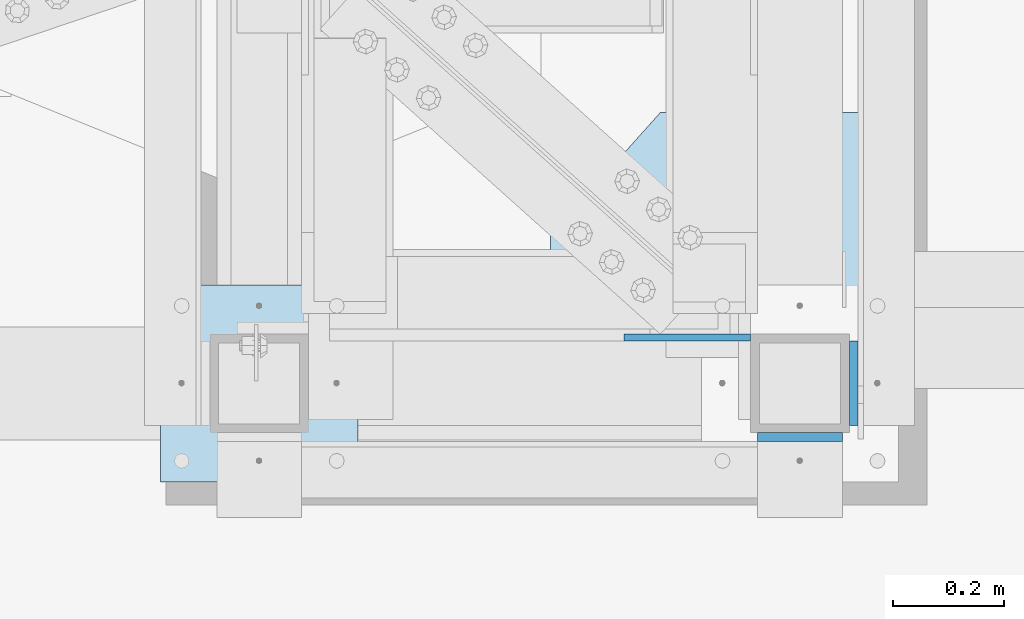
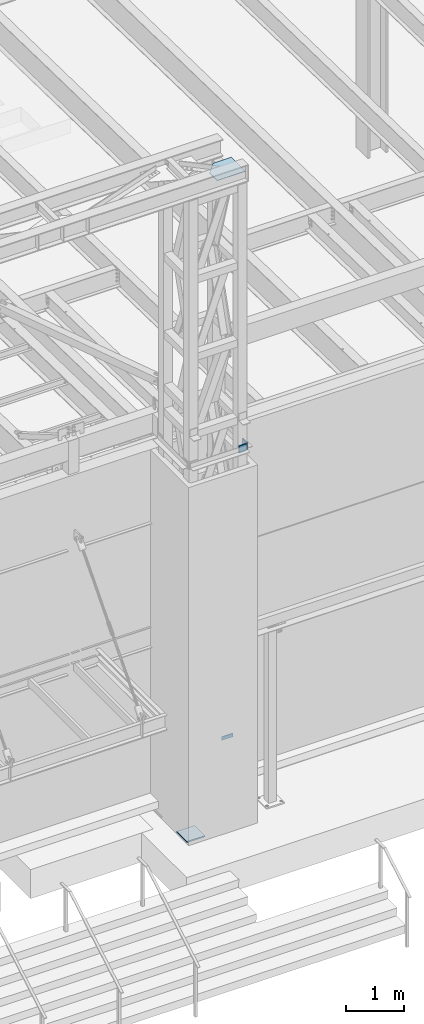
# One storey, part 1476 of 1763: 5 plates, 2 elements without a shape of their own.
"""IFC2X3 building model written with IfcOpenShell, lengths in millimetres."""

from ifc_helpers import new_model, si_unit, frame, origin_with_axes, place, context, subcontext, project, spatial, faceted_brep, material, type_object, element, aggregate, save


model = new_model("IFC2X3")

# Units and contexts
model_context = context("Model", 3, precision=1e-05, world=origin_with_axes())
body_context = subcontext(model_context, "Body", "Model", "MODEL_VIEW")
ifc_project = project(units=[si_unit("LENGTHUNIT", "METRE", prefix="MILLI"), si_unit("AREAUNIT", "SQUARE_METRE"), si_unit("VOLUMEUNIT", "CUBIC_METRE"), si_unit("MASSUNIT", "GRAM", prefix="KILO"), si_unit("TIMEUNIT", "SECOND"), si_unit("PLANEANGLEUNIT", "RADIAN"), si_unit("SOLIDANGLEUNIT", "STERADIAN"), si_unit("THERMODYNAMICTEMPERATUREUNIT", "DEGREE_CELSIUS"), si_unit("LUMINOUSINTENSITYUNIT", "LUMEN")], contexts=[model_context])

# Site, building, storey
site_placement = place(None, origin_with_axes())
site = spatial("IfcSite", under=ifc_project, at=site_placement, CompositionType="ELEMENT")
building_placement = place(site_placement, origin_with_axes())
building = spatial("IfcBuilding", under=site, at=building_placement, Name="Undefined", CompositionType="ELEMENT")
storey_placement = place(building_placement, origin_with_axes())
storey = spatial("IfcBuildingStorey", under=building, at=storey_placement, Name="Undefined", CompositionType="ELEMENT", Elevation=0.0)

# Assembly, plates
assembly_1_placement = place(storey_placement, origin_with_axes())
assembly_1 = element("IfcElementAssembly", 1, at=assembly_1_placement, inside=storey, Name="FRAME", AssemblyPlace="NOTDEFINED", PredefinedType="RIGID_FRAME")
ifc_material = material(Name="STEEL/A36")
plate_type_1 = type_object("IfcPlateType", PredefinedType="NOTDEFINED")
plate_1_placement = place(assembly_1_placement, frame((-47078.3270385205, -15370.1772094127, 6845.29999694824), z_axis=(0.99999999999718, 2.37500000002911e-06, 0.0), x_axis=(0.0, 0.0, -1.0)))
plate_1 = element("IfcPlate", 2, at=plate_1_placement, type_object=plate_type_1, material=ifc_material, Name="PLATE", context=body_context, shape_type="Brep", body=[
    faceted_brep([(0.0, -6.34999999999491, 1.45519152283669e-11), (0.0, -6.35000000001855, 228.600006104178), (0.0, 6.34999999996944, 228.600006104134), (0.0, 6.34999999999491, -2.91038304567337e-11), (76.1999969482422, -6.35000000001855, 228.600006104178), (76.1999969482422, 6.34999999996944, 228.600006104134), (76.1999969482422, -6.34999999999491, 1.45519152283669e-11), (76.1999969482422, 6.34999999999491, -2.91038304567337e-11)], [[[0, 1, 2, 3]], [[1, 4, 5, 2]], [[4, 6, 7, 5]], [[6, 0, 3, 7]], [[5, 7, 3, 2]], [[6, 4, 1, 0]]]),
])
plate_type_2 = type_object("IfcPlateType", PredefinedType="NOTDEFINED")
plate_2_placement = place(assembly_1_placement, frame((-47913.3523997267, -15274.9272094127, 5080.0), z_axis=(1.0, 0.0, 0.0), x_axis=(0.0, -1.0, 0.0)))
plate_2 = element("IfcPlate", 3, at=plate_2_placement, type_object=plate_type_2, material=ifc_material, Name="PLATE", context=body_context, shape_type="Brep", body=[
    faceted_brep([(0.0, -12.6999999999971, -1.81898940354586e-12), (0.0, -12.6999999999998, 355.600006103516), (0.0, 12.6999999999998, 355.600006103516), (0.0, 12.6999999999971, -1.81898940354586e-12), (355.600006103516, -12.6999999999998, 355.600006103516), (355.600006103516, 12.6999999999998, 355.600006103516), (355.600006103516, -12.6999999999998, 0.0), (355.600006103516, 12.6999999999998, 0.0)], [[[0, 1, 2, 3]], [[1, 4, 5, 2]], [[4, 6, 7, 5]], [[6, 0, 3, 7]], [[5, 7, 3, 2]], [[6, 4, 1, 0]]]),
])
plate_type_3 = type_object("IfcPlateType", PredefinedType="NOTDEFINED")
plate_3_placement = place(assembly_1_placement, frame((-46663.9897044142, -15528.9272094127, 12979.4), z_axis=(0.0, 0.0, -1.0), x_axis=(0.0, 1.0, 0.0)))
plate_3 = element("IfcPlate", 4, at=plate_3_placement, type_object=plate_type_3, material=ifc_material, Name="PLATE", context=body_context, shape_type="Brep", body=[
    faceted_brep([(-7.27595761418343e-12, -7.9375, 0.0), (7.27595761418343e-12, -7.9375, 152.399993896484), (7.27595761418343e-12, 7.9375, 152.399993896484), (-7.27595761418343e-12, 7.9375, 0.0), (152.399993896484, -7.9375, 152.399993896484), (152.399993896484, 7.9375, 152.399993896484), (152.399993896484, -7.9375, -1.81898940354586e-12), (152.399993896484, 7.9375, -1.81898940354586e-12)], [[[0, 1, 2, 3]], [[1, 4, 5, 2]], [[4, 6, 7, 5]], [[6, 0, 3, 7]], [[5, 7, 3, 2]], [[6, 4, 1, 0]]]),
])
plate_4_placement = place(assembly_1_placement, frame((-46684.6272044142, -15549.5647094127, 12979.4), z_axis=(0.0, 0.0, -1.0), x_axis=(-1.0, 0.0, 0.0)))
plate_4 = element("IfcPlate", 5, at=plate_4_placement, type_object=plate_type_3, material=ifc_material, Name="PLATE", context=body_context, shape_type="Brep", body=[
    faceted_brep([(-7.27595761418343e-12, -7.9375, 0.0), (7.27595761418343e-12, -7.9375, 152.399993896484), (7.27595761418343e-12, 7.9375, 152.399993896484), (-7.27595761418343e-12, 7.9375, 0.0), (152.399993896484, -7.9375, 152.399993896484), (152.399993896484, 7.9375, 152.399993896484), (152.399993896484, -7.9375, -1.81898940354586e-12), (152.399993896484, 7.9375, -1.81898940354586e-12)], [[[0, 1, 2, 3]], [[1, 4, 5, 2]], [[4, 6, 7, 5]], [[6, 0, 3, 7]], [[5, 7, 3, 2]], [[6, 4, 1, 0]]]),
])
aggregate(assembly_1, [plate_1, plate_3, plate_4, plate_2])

# Assembly, plate
assembly_2_placement = place(storey_placement, origin_with_axes())
assembly_2 = element("IfcElementAssembly", 6, at=assembly_2_placement, inside=storey, Name="BEAM", AssemblyPlace="NOTDEFINED", PredefinedType="RIGID_FRAME")
plate_type_4 = type_object("IfcPlateType", PredefinedType="NOTDEFINED")
plate_5_placement = place(assembly_2_placement, frame((-46646.4815846583, -15447.9647094127, 18616.6125), z_axis=(0.0, 1.0, 0.0), x_axis=(-1.0, 0.0, 0.0)))
plate_5 = element("IfcPlate", 7, at=plate_5_placement, type_object=plate_type_4, material=ifc_material, Name="PLATE", context=body_context, shape_type="Brep", body=[
    faceted_brep([(0.0, -4.76249999999982, 0.0), (-2.89212766801938e-06, -4.76250000000073, 483.159637451172), (-2.89212766801938e-06, 4.76250000000073, 483.159637451172), (0.0, 4.76249999999982, 0.0), (366.449584962225, -4.76250000000073, 483.159637450863), (366.449584962225, 4.76250000000073, 483.159637450863), (564.478271485066, -4.76250000000073, 262.082977294443), (564.478271485066, 4.76250000000073, 262.082977294443), (564.478271484375, -4.76250000000073, -4.38376446254551e-10), (564.478271484375, 4.76250000000073, -4.38376446254551e-10)], [[[0, 1, 2, 3]], [[1, 4, 5, 2]], [[4, 6, 7, 5]], [[6, 8, 9, 7]], [[8, 0, 3, 9]], [[5, 7, 9, 3, 2]], [[8, 6, 4, 1, 0]]]),
])
aggregate(assembly_2, [plate_5])

save(model, "model.ifc")
